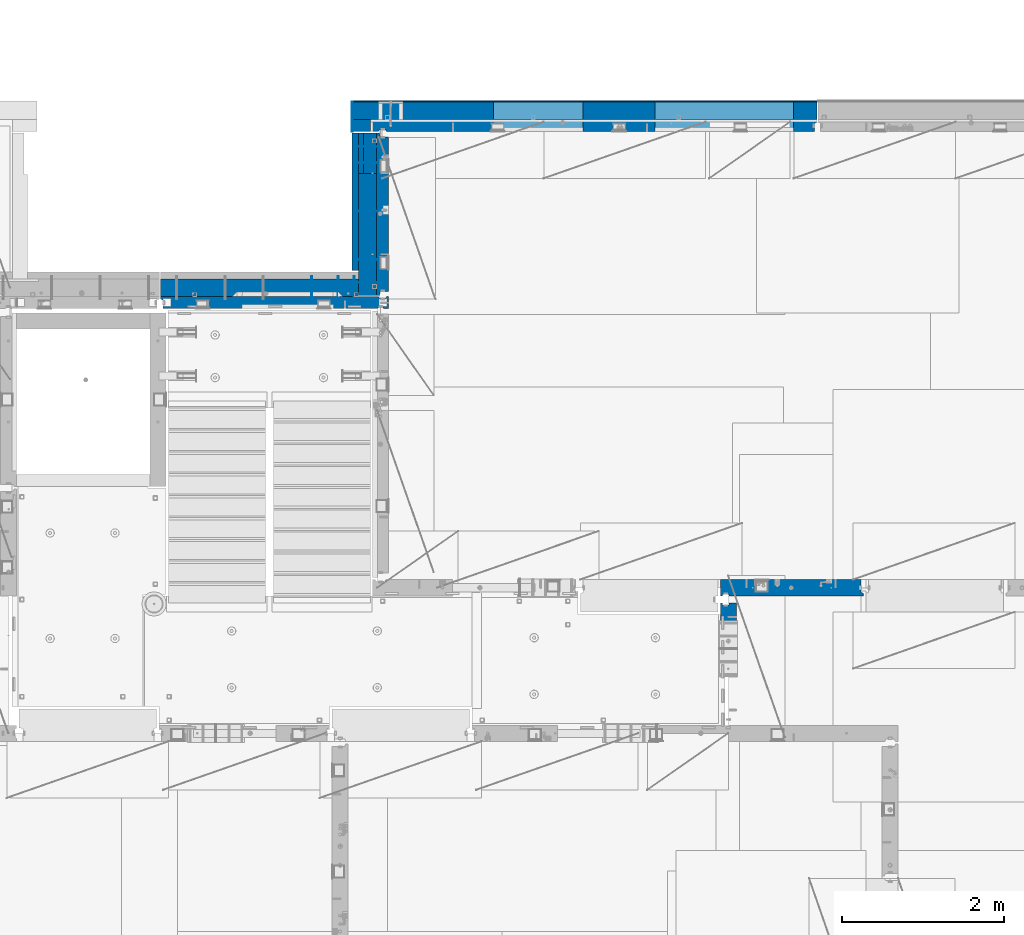
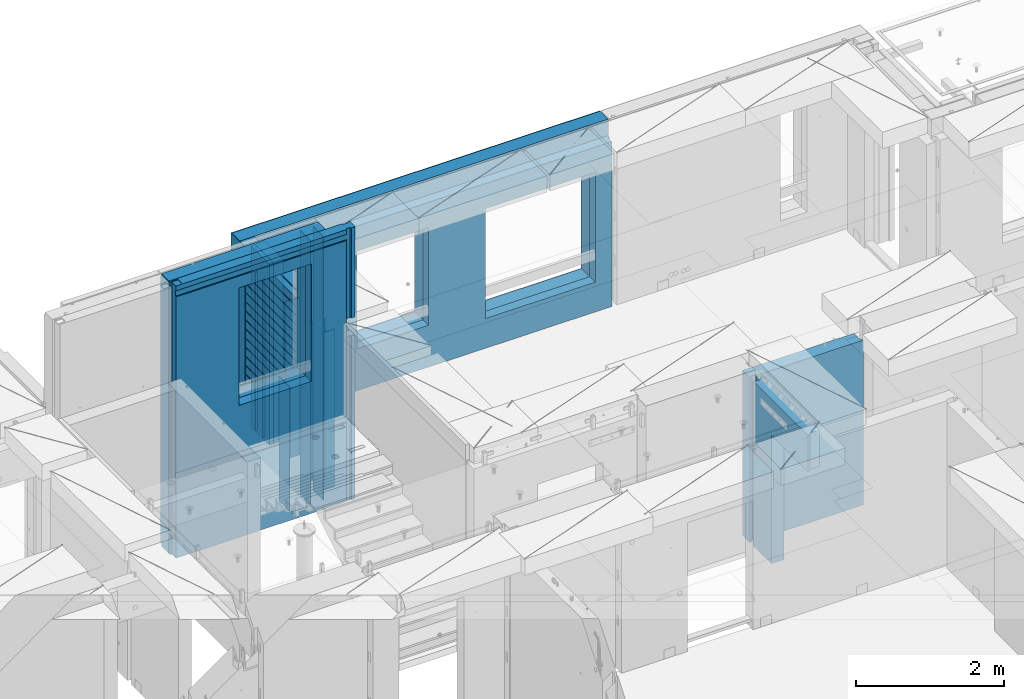
# One storey, part 219 of 325: 22 walls, 7 elements without a shape of their own.
"""IFC2X3 building model written with IfcOpenShell, lengths in millimetres."""

import ifcopenshell
import ifcopenshell.guid

model = None  # the IFC model being written
_history = None  # IfcOwnerHistory: only IFC2X3 demands one
_inside = {}  # id of a spatial element -> (the spatial element, [elements in it])
_under = {}  # id of a project, library or spatial element -> (it, [spatial elements below it])
_declared = {}  # id of a project -> (the project, [libraries it declares])
_typed = {}  # id of a type object -> (the type object, [elements of that type])
_made_of = {}  # id of a material, layer set ... -> (it, [elements and type objects made of it])


def new_model(schema):
    """Start an empty IFC model of exactly this schema.

    Asked for "IFC4X3", IfcOpenShell would pick the latest addendum, in which some entities
    have other attributes; the version numbers below select the first issue.
    IFC2X3 requires an IfcOwnerHistory on every rooted entity: one is made here for all.
    """
    global model, _history
    if schema == "IFC4X3":
        model = ifcopenshell.file(schema_version=(4, 3, 0, 0))
    else:
        model = ifcopenshell.file(schema=schema)
    _inside.clear()
    _under.clear()
    _declared.clear()
    _typed.clear()
    _made_of.clear()
    _history = None
    if model.schema == "IFC2X3":
        org = make("IfcOrganization", Name="unknown")
        user = make(
            "IfcPersonAndOrganization",
            ThePerson=make("IfcPerson", FamilyName="unknown"),
            TheOrganization=org,
        )
        app = make(
            "IfcApplication",
            ApplicationDeveloper=org,
            Version="unknown",
            ApplicationFullName="unknown",
            ApplicationIdentifier="unknown",
        )
        _history = make(
            "IfcOwnerHistory",
            OwningUser=user,
            OwningApplication=app,
            ChangeAction="ADDED",
            CreationDate=0,
        )
    return model


def make(cls, **values):
    """One entity of the class cls with the attributes given. An attribute that is None is left unset."""
    return model.create_entity(
        cls, **{name: value for name, value in values.items() if value is not None}
    )


def rooted(cls, **values):
    """An entity with a GlobalId (a new one), such as an element, a storey or a relation."""
    return make(cls, GlobalId=ifcopenshell.guid.new(), OwnerHistory=_history, **values)


def si_unit(unit_type, name, prefix=None):
    """IfcSIUnit, for example si_unit("LENGTHUNIT", "METRE", prefix="MILLI")."""
    return make("IfcSIUnit", UnitType=unit_type, Prefix=prefix, Name=name)


def assignment(units):
    """IfcUnitAssignment: the units of a project."""
    return None if units is None else make("IfcUnitAssignment", Units=units)


def point(xyz):
    """IfcCartesianPoint."""
    return None if xyz is None else make("IfcCartesianPoint", Coordinates=xyz)


def direction(xyz):
    """IfcDirection."""
    return None if xyz is None else make("IfcDirection", DirectionRatios=xyz)


def frame(location, z_axis=None, x_axis=None):
    """IfcAxis2Placement3D, a coordinate frame: its origin and axes. An axis left out is left unset."""
    return make(
        "IfcAxis2Placement3D",
        Location=point(location),
        Axis=direction(z_axis),
        RefDirection=direction(x_axis),
    )


def origin_with_axes():
    """The frame at (0, 0, 0) with the z axis (0, 0, 1) and the x axis (1, 0, 0) written out."""
    return frame((0.0, 0.0, 0.0), z_axis=(0.0, 0.0, 1.0), x_axis=(1.0, 0.0, 0.0))


def place(relative_to, where):
    """IfcLocalPlacement: puts the frame where relative to a parent placement (None: the world)."""
    return make(
        "IfcLocalPlacement", PlacementRelTo=relative_to, RelativePlacement=where
    )


def context(
    kind, dimensions, precision=None, world=None, true_north=None, identifier=None
):
    """IfcGeometricRepresentationContext, for example the 3D "Model" context."""
    return make(
        "IfcGeometricRepresentationContext",
        ContextIdentifier=identifier,
        ContextType=kind,
        CoordinateSpaceDimension=dimensions,
        Precision=precision,
        WorldCoordinateSystem=world,
        TrueNorth=true_north,
    )


def subcontext(parent, identifier, kind, view, scale=None):
    """IfcGeometricRepresentationSubContext, for example "Body" below "Model"."""
    return make(
        "IfcGeometricRepresentationSubContext",
        ContextIdentifier=identifier,
        ContextType=kind,
        ParentContext=parent,
        TargetScale=scale,
        TargetView=view,
    )


def project(units=None, contexts=None):
    """IfcProject with its units and contexts."""
    return rooted(
        "IfcProject",
        Name="project",
        RepresentationContexts=contexts,
        UnitsInContext=assignment(units),
    )


def spatial(cls, under=None, at=None, **own):
    """A site, building, storey or space (cls), placed at a placement, below another one or the project."""
    s = rooted(cls, ObjectPlacement=at, **own)
    if under is not None:
        _under.setdefault(under.id(), (under, []))[1].append(s)
    return s


def faces_of(points, faces, orient=None, outer=None):
    """IfcFace entities. A face is a list of loops; a loop is a list of indices into points, from 0.

    orient and outer hold one flag for each loop. By default every Orientation is true, the
    first loop of a face is its IfcFaceOuterBound and the others are IfcFaceBound.
    """
    made = []
    for i, loops in enumerate(faces):
        bounds = []
        for j, loop in enumerate(loops):
            is_outer = j == 0 if outer is None else outer[i][j]
            bounds.append(
                make(
                    "IfcFaceOuterBound" if is_outer else "IfcFaceBound",
                    Bound=make("IfcPolyLoop", Polygon=[points[k] for k in loop]),
                    Orientation=True if orient is None else orient[i][j],
                )
            )
        made.append(make("IfcFace", Bounds=bounds))
    return made


def faceted_brep(points, faces, orient=None, outer=None, voids=None):
    """IfcFacetedBrep: a solid bounded by flat faces; with voids (closed shells), ...WithVoids."""
    shared = [point(p) for p in points]
    hull = make("IfcClosedShell", CfsFaces=faces_of(shared, faces, orient, outer))
    if voids is None:
        return make("IfcFacetedBrep", Outer=hull)
    return make(
        "IfcFacetedBrepWithVoids",
        Outer=hull,
        Voids=[
            make(cls, CfsFaces=faces_of(shared, fs, o, b)) for cls, fs, o, b in voids
        ],
    )


def shape(context_of_items, identifier, shape_type, items):
    """IfcShapeRepresentation: the items that make up one representation, for example the "Body"."""
    return make(
        "IfcShapeRepresentation",
        ContextOfItems=context_of_items,
        RepresentationIdentifier=identifier,
        RepresentationType=shape_type,
        Items=items,
    )


def material(Name=None, Category=None):
    """IfcMaterial."""
    return make("IfcMaterial", Name=Name, Category=Category)


def made_of(thing, what):
    """Note that an element or type object is made of a material, layer set ...; save() writes the relation."""
    if what is not None:
        _made_of.setdefault(what.id(), (what, []))[1].append(thing)
    return thing


def type_object(cls, material=None, **own):
    """A type object (cls), such as IfcWallType, which elements share."""
    return made_of(rooted(cls, **own), material)


def element(
    cls,
    number,
    at=None,
    inside=None,
    cuts=None,
    type_object=None,
    material=None,
    context=None,
    identifier="Body",
    shape_type=None,
    held_by="IfcProductDefinitionShape",
    body=None,
    shapes=None,
    **own,
):
    """One element of the class cls, such as IfcWall. Its Tag is "e" and its number.

    at: its placement. inside: the storey or other place that contains it. cuts: it is an
    opening in that element (IfcRelVoidsElement). A single representation is given by context,
    identifier, shape_type and body (its items); several are given by shapes. held_by: the class
    of the entity that holds the representations. save() writes the other relations.
    """
    e = rooted(cls, Tag="e%d" % number, ObjectPlacement=at, **own)
    if body is not None:
        shapes = [shape(context, identifier, shape_type, body)]
    if shapes is not None:
        e.Representation = make(held_by, Representations=shapes)
    if inside is not None:
        _inside.setdefault(inside.id(), (inside, []))[1].append(e)
    if cuts is not None:
        rooted(
            "IfcRelVoidsElement", RelatingBuildingElement=cuts, RelatedOpeningElement=e
        )
    if type_object is not None:
        _typed.setdefault(type_object.id(), (type_object, []))[1].append(e)
    return made_of(e, material)


def aggregate(whole, parts):
    """IfcRelAggregates: a whole, such as a stair, and the parts it consists of."""
    return rooted("IfcRelAggregates", RelatingObject=whole, RelatedObjects=parts)


def save(model, path):
    """Write the relations noted so far, then the file.

    IfcRelAggregates (storeys below a building ...), IfcRelContainedInSpatialStructure (elements
    in a storey), IfcRelDefinesByType, IfcRelAssociatesMaterial and IfcRelDeclares: one each for
    every whole, place, type object, material and project.
    """
    for whole, parts in _under.values():
        aggregate(whole, parts)
    for where, things in _inside.values():
        rooted(
            "IfcRelContainedInSpatialStructure",
            RelatedElements=things,
            RelatingStructure=where,
        )
    for kind, things in _typed.values():
        rooted("IfcRelDefinesByType", RelatedObjects=things, RelatingType=kind)
    for what, things in _made_of.values():
        rooted("IfcRelAssociatesMaterial", RelatedObjects=things, RelatingMaterial=what)
    for by, libraries in _declared.values():
        rooted("IfcRelDeclares", RelatingContext=by, RelatedDefinitions=libraries)
    model.write(path)


model = new_model("IFC2X3")

# Units and contexts
model_context = context("Model", 3, precision=1e-05, world=origin_with_axes())
body_context = subcontext(model_context, "Body", "Model", "MODEL_VIEW")
ifc_project = project(units=[si_unit("LENGTHUNIT", "METRE", prefix="MILLI"), si_unit("AREAUNIT", "SQUARE_METRE"), si_unit("VOLUMEUNIT", "CUBIC_METRE"), si_unit("MASSUNIT", "GRAM", prefix="KILO"), si_unit("TIMEUNIT", "SECOND"), si_unit("PLANEANGLEUNIT", "RADIAN"), si_unit("SOLIDANGLEUNIT", "STERADIAN"), si_unit("THERMODYNAMICTEMPERATUREUNIT", "DEGREE_CELSIUS"), si_unit("LUMINOUSINTENSITYUNIT", "LUMEN")], contexts=[model_context])

# Site, building, storey
site_placement = place(None, origin_with_axes())
site = spatial("IfcSite", under=ifc_project, at=site_placement, CompositionType="ELEMENT")
building_placement = place(site_placement, origin_with_axes())
building = spatial("IfcBuilding", under=site, at=building_placement, CompositionType="ELEMENT")
storey_placement = place(building_placement, origin_with_axes())
storey = spatial("IfcBuildingStorey", under=building, at=storey_placement, Name="1", CompositionType="ELEMENT", Elevation=0.0)

# Assembly, walls
assembly_1_placement = place(storey_placement, origin_with_axes())
assembly_1 = element("IfcElementAssembly", 1, at=assembly_1_placement, inside=storey, Name="(PD)", AssemblyPlace="NOTDEFINED", PredefinedType="REINFORCEMENT_UNIT")
ifc_material_1 = material(Name="Undefined")
wall_type_1 = type_object("IfcWallType", PredefinedType="NOTDEFINED")
wall_1_placement = place(assembly_1_placement, frame((22010.0, 21035.0, 83115.0), z_axis=(0.0, 0.0, 1.0), x_axis=(1.0, 0.0, 0.0)))
wall_1 = element("IfcWall", 2, at=wall_1_placement, type_object=wall_type_1, material=ifc_material_1, Name="(PD)", context=body_context, shape_type="Brep", body=[
    faceted_brep([(0.0, 5.0, -1300.0), (0.0, 5.0, 1300.0), (280.0, 5.0, 1300.0), (280.0, 5.0, -1300.0), (0.0, -5.0, 1300.0), (280.0, -5.0, 1300.0), (0.0, -5.0, -1300.0), (280.0, -5.0, -1300.0)], [[[0, 1, 2, 3]], [[1, 4, 5, 2]], [[4, 6, 7, 5]], [[6, 0, 3, 7]], [[5, 7, 3, 2]], [[6, 4, 1, 0]]]),
])
wall_2_placement = place(assembly_1_placement, frame((22010.0, 21635.0, 83115.0), z_axis=(0.0, 0.0, 1.0), x_axis=(1.0, 0.0, 0.0)))
wall_2 = element("IfcWall", 3, at=wall_2_placement, type_object=wall_type_1, material=ifc_material_1, Name="(PD)", context=body_context, shape_type="Brep", body=[
    faceted_brep([(0.0, 5.0, -1300.0), (0.0, 5.0, 1300.0), (280.0, 5.0, 1300.0), (280.0, 5.0, -1300.0), (0.0, -5.0, 1300.0), (280.0, -5.0, 1300.0), (0.0, -5.0, -1300.0), (280.0, -5.0, -1300.0)], [[[0, 1, 2, 3]], [[1, 4, 5, 2]], [[4, 6, 7, 5]], [[6, 0, 3, 7]], [[5, 7, 3, 2]], [[6, 4, 1, 0]]]),
])
wall_3_placement = place(assembly_1_placement, frame((22010.0, 22235.0, 83115.0), z_axis=(0.0, 0.0, 1.0), x_axis=(1.0, 0.0, 0.0)))
wall_3 = element("IfcWall", 4, at=wall_3_placement, type_object=wall_type_1, material=ifc_material_1, Name="(PD)", context=body_context, shape_type="Brep", body=[
    faceted_brep([(0.0, 5.0, -1300.0), (0.0, 5.0, 1300.0), (280.0, 5.0, 1300.0), (280.0, 5.0, -1300.0), (0.0, -5.0, 1300.0), (280.0, -5.0, 1300.0), (0.0, -5.0, -1300.0), (280.0, -5.0, -1300.0)], [[[0, 1, 2, 3]], [[1, 4, 5, 2]], [[4, 6, 7, 5]], [[6, 0, 3, 7]], [[5, 7, 3, 2]], [[6, 4, 1, 0]]]),
])

# Assembly, wall
assembly_2_placement = place(storey_placement, origin_with_axes())
assembly_2 = element("IfcElementAssembly", 5, at=assembly_2_placement, inside=storey, Name="Steel Assembly", AssemblyPlace="NOTDEFINED", PredefinedType="NOTDEFINED")
wall_4_placement = place(assembly_2_placement, frame((22269.7, 20754.999997361, 83110.0), z_axis=(0.0, 0.0, 1.0), x_axis=(-1.0, 3.00000001838171e-08, 0.0)))
wall_4 = element("IfcWall", 6, at=wall_4_placement, type_object=wall_type_1, material=ifc_material_1, Name="(PD)", context=body_context, shape_type="Brep", body=[
    faceted_brep([(0.0, 5.0, -1300.0), (0.0, 5.0, 1300.0), (280.0, 5.0, 1300.0), (280.0, 5.0, -1300.0), (0.0, -5.0, 1300.0), (280.0, -5.0, 1300.0), (0.0, -5.0, -1300.0), (280.0, -5.0, -1300.0)], [[[0, 1, 2, 3]], [[1, 4, 5, 2]], [[4, 6, 7, 5]], [[6, 0, 3, 7]], [[5, 7, 3, 2]], [[6, 4, 1, 0]]]),
])
aggregate(assembly_2, [wall_4])

# Wall
wall_5_placement = place(assembly_1_placement, frame((22010.0, 22435.0, 83115.0), z_axis=(0.0, 0.0, 1.0), x_axis=(1.0, 0.0, 0.0)))
wall_5 = element("IfcWall", 7, at=wall_5_placement, type_object=wall_type_1, material=ifc_material_1, Name="(PD)", context=body_context, shape_type="Brep", body=[
    faceted_brep([(0.0, 5.0, -1300.0), (0.0, 5.0, 1300.0), (280.0, 5.0, 1300.0), (280.0, 5.0, -1300.0), (0.0, -5.0, 1300.0), (280.0, -5.0, 1300.0), (0.0, -5.0, -1300.0), (280.0, -5.0, -1300.0)], [[[0, 1, 2, 3]], [[1, 4, 5, 2]], [[4, 6, 7, 5]], [[6, 0, 3, 7]], [[5, 7, 3, 2]], [[6, 4, 1, 0]]]),
])

# Assembly, wall
assembly_3_placement = place(storey_placement, origin_with_axes())
assembly_3 = element("IfcElementAssembly", 8, at=assembly_3_placement, inside=storey, AssemblyPlace="NOTDEFINED", PredefinedType="REINFORCEMENT_UNIT")
ifc_material_2 = material(Name="CONCRETE/C25/30")
wall_type_2 = type_object("IfcWallType", PredefinedType="NOTDEFINED")
wall_6_placement = place(assembly_3_placement, frame((26510.0014364077, 16980.0, 83112.5), z_axis=(0.0, 0.0, 1.0), x_axis=(1.0, 0.0, 0.0)))
wall_6 = element("IfcWall", 9, at=wall_6_placement, type_object=wall_type_2, material=ifc_material_2, context=body_context, shape_type="Brep", body=[
    faceted_brep([(1739.99847412109, 100.0, 1357.5), (1739.99847412109, -57.0, 1357.5), (1739.99847412109, -57.0, -1357.5), (1739.99847412109, 100.0, -1357.5), (1769.99847412109, -70.0, 1357.5), (1769.99847412109, -70.0, -1357.5), (0.0, -100.0, -1357.5), (0.0, -100.0, 1357.5), (0.0, 100.0, 1357.5), (0.0, 100.0, -1357.5), (29.998563592264, -100.0, -1357.5), (29.998563592264, -100.0, 1357.5), (29.998563592264, -80.0008544921875, -1357.5), (29.998563592264, -80.0008544921875, 1357.5), (109.998563592264, -80.0008544921875, -1357.5), (109.998563592264, -80.0008544921875, 1357.5), (109.998563592264, -100.0, -1357.5), (109.998563592264, -100.0, 1357.5), (1769.99847412109, -100.0, -1357.5), (1769.99847412109, -100.0, 1357.5)], [[[0, 1, 2, 3]], [[4, 5, 2, 1]], [[6, 7, 8, 9]], [[7, 6, 10, 11]], [[11, 10, 12, 13]], [[13, 12, 14, 15]], [[15, 14, 16, 17]], [[18, 19, 17, 16]], [[0, 8, 7, 11, 13, 15, 17, 19, 4, 1]], [[9, 8, 0, 3]], [[18, 16, 14, 12, 10, 6, 9, 3, 2, 5]], [[19, 18, 5, 4]]]),
])
aggregate(assembly_3, [wall_6])

assembly_4_placement = place(storey_placement, origin_with_axes())
assembly_4 = element("IfcElementAssembly", 10, at=assembly_4_placement, inside=storey, AssemblyPlace="NOTDEFINED", PredefinedType="REINFORCEMENT_UNIT")
wall_7_placement = place(assembly_4_placement, frame((26609.9991475894, 15280.0004107749, 83112.5), z_axis=(0.0, 0.0, 1.0), x_axis=(0.0, 1.0, 0.0)))
wall_7 = element("IfcWall", 11, at=wall_7_placement, type_object=wall_type_2, material=ifc_material_2, context=body_context, shape_type="Brep", body=[
    faceted_brep([(1509.99949975397, 70.0, 1357.5), (1489.99949975397, 70.0, 1357.5), (1489.99949975397, 70.0, -1357.5), (1509.99949975397, 70.0, -1357.5), (1489.99949975397, -10.0, 1357.5), (1489.99949975397, -10.0, -1357.5), (1509.99949975397, -10.0, 1357.5), (1509.99949975397, -10.0, -1357.5), (29.9995892251427, 70.0, 1357.5), (29.9995892251427, 70.0, 762.5), (59.9995892251427, 57.0, 762.5), (59.9995892251427, 57.0, 1357.5), (29.9995892251427, 100.0, 1357.5), (29.9995892251427, 100.0, 762.5), (1509.99949975397, 100.0, 1357.5), (1509.99949975397, 100.0, -1357.5), (1019.99979369292, 100.0, -1357.5), (1019.99979369292, 100.0, 762.5), (1019.99979369292, -100.0, 762.5), (1019.99979369292, -100.0, -1357.5), (59.9995892251427, -100.0, 762.5), (59.9995892251427, -100.0, 1357.5), (1509.99949975397, -100.0, -1357.5), (1509.99949975397, -100.0, 1357.5)], [[[0, 1, 2, 3]], [[4, 5, 2, 1]], [[6, 7, 5, 4]], [[8, 9, 10, 11]], [[12, 13, 9, 8]], [[12, 14, 15, 16, 17, 13]], [[18, 17, 16, 19]], [[9, 13, 17, 18, 20, 10]], [[21, 11, 10, 20]], [[18, 19, 22, 23, 21, 20]], [[1, 0, 14, 12, 8, 11, 21, 23, 6, 4]], [[15, 14, 0, 3]], [[22, 19, 16, 15, 3, 2, 5, 7]], [[23, 22, 7, 6]]]),
])
aggregate(assembly_4, [wall_7])

# Wall
ifc_material_3 = material(Name="COS5gt")
wall_type_3 = type_object("IfcWallType", PredefinedType="NOTDEFINED")
wall_8_placement = place(assembly_1_placement, frame((22150.0, 20595.0, 83247.5), z_axis=(0.0, 0.0, 1.0), x_axis=(0.0, 1.0, 0.0)))
wall_8 = element("IfcWall", 12, at=wall_8_placement, type_object=wall_type_3, material=ifc_material_3, context=body_context, shape_type="Brep", body=[
    faceted_brep([(285.0, 110.0, -1492.5), (285.0, 110.0, -1442.5), (285.0, 90.0, -1442.5), (285.0, 90.0, -1492.5), (1510.0, 90.0, -1442.5), (1510.0, 110.0, -1442.5), (1510.0, 90.0, -1492.5), (0.0, -110.0, -1492.5), (0.0, -110.0, 1492.5), (0.0, 110.0, 1492.5), (0.0, 110.0, -1492.5), (1510.0, -110.0, -1492.5), (1510.0, -110.0, 1492.5), (285.0, 110.0, 1492.5), (1510.0, 90.0, 1492.5), (285.0, 90.0, 1492.5), (285.0, 90.0, 1442.5), (285.0, 110.0, 1442.5), (1510.0, 90.0, 1442.5), (1510.0, 110.0, 1442.5)], [[[0, 1, 2, 3]], [[4, 2, 1, 5]], [[6, 3, 2, 4]], [[7, 8, 9, 10]], [[8, 7, 11, 12]], [[13, 9, 8, 12, 14, 15]], [[15, 16, 17, 13]], [[14, 18, 16, 15]], [[19, 17, 16, 18]], [[0, 10, 9, 13, 17, 19, 5, 1]], [[11, 7, 10, 0, 3, 6]], [[19, 18, 14, 12, 11, 6, 4, 5]]]),
])

# Assembly, walls
assembly_5_placement = place(storey_placement, origin_with_axes())
assembly_5 = element("IfcElementAssembly", 13, at=assembly_5_placement, inside=storey, AssemblyPlace="NOTDEFINED", PredefinedType="REINFORCEMENT_UNIT")
ifc_material_4 = material()
wall_9_placement = place(assembly_5_placement, frame((22075.0, 22620.0, 83247.5), z_axis=(0.0, 0.0, 1.0), x_axis=(0.0, 1.0, 0.0)))
wall_9 = element("IfcWall", 14, at=wall_9_placement, type_object=wall_type_3, material=ifc_material_4, context=body_context, shape_type="Brep", body=[
    faceted_brep([(0.0, 110.0, -1492.5), (0.0, 110.0, 1492.5), (150.0, 110.0, 1492.5), (150.0, 110.0, -1492.5), (0.0, -110.0, 1492.5), (150.0, -110.0, 1492.5), (0.0, -110.0, -1492.5), (150.0, -110.0, -1492.5)], [[[0, 1, 2, 3]], [[1, 4, 5, 2]], [[4, 6, 7, 5]], [[6, 0, 3, 7]], [[5, 7, 3, 2]], [[6, 4, 1, 0]]]),
])
wall_10_placement = place(assembly_5_placement, frame((22260.0, 22880.0, 83247.5), z_axis=(0.0, 0.0, 1.0), x_axis=(1.0, 0.0, 0.0)))
wall_10 = element("IfcWall", 15, at=wall_10_placement, type_object=wall_type_3, material=ifc_material_4, context=body_context, shape_type="Brep", body=[
    faceted_brep([(-295.0, 110.0, 1492.5), (-295.0, -110.0, 1492.5), (5445.0, -110.0, 1492.5), (5445.0, 110.0, 1492.5), (-295.0, -110.0, -1492.5), (-295.0, 110.0, -1492.5), (5445.0, 110.0, -1492.5), (5445.0, -110.0, -1492.5), (3445.00100868184, 110.0, -1002.5), (5155.00100868184, 110.0, -1002.5), (5155.00100868184, 110.0, 807.5), (3445.00100868184, 110.0, 807.5), (1444.99910133321, 110.0, -802.5), (2554.99910133321, 110.0, -802.5), (2554.99910133321, 110.0, 807.5), (1444.99910133321, 110.0, 807.5), (1444.99910133321, -110.0, -802.5), (2554.99910133321, -110.0, -802.5), (1444.99910133321, -110.0, 807.5), (2554.99910133321, -110.0, 807.5), (3445.00100868184, -110.0, -1002.5), (3445.00100868184, -110.0, 807.5), (5155.00100868184, -110.0, 807.5), (5155.00100868184, -110.0, -1002.5)], [[[0, 1, 2, 3]], [[4, 1, 0, 5]], [[4, 5, 6, 7]], [[2, 7, 6, 3]], [[5, 0, 3, 6], [8, 9, 10, 11], [12, 13, 14, 15]], [[12, 16, 17, 13]], [[15, 18, 16, 12]], [[14, 19, 18, 15]], [[13, 17, 19, 14]], [[1, 4, 7, 2], [20, 21, 22, 23], [16, 18, 19, 17]], [[10, 22, 21, 11]], [[9, 23, 22, 10]], [[8, 20, 23, 9]], [[11, 21, 20, 8]]]),
])

# Wall
ifc_material_5 = material(Name="CONCRETE/C30/37")
wall_type_4 = type_object("IfcWallType", PredefinedType="NOTDEFINED")
wall_11_placement = place(assembly_1_placement, frame((21997.5, 20900.0, 83247.5), z_axis=(0.0, 0.0, 1.0), x_axis=(0.0, 1.0, 0.0)))
wall_11 = element("IfcWall", 16, at=wall_11_placement, type_object=wall_type_4, material=ifc_material_5, context=body_context, shape_type="Brep", body=[
    faceted_brep([(1705.0, 42.5, 1343.0), (0.0, 42.5, 1342.99999994476), (-3.63797880709171e-12, 32.4999992507037, 1344.99999999926), (1705.0, 32.5, 1345.0), (1705.0, 32.5, 1355.0), (-3.63797880709171e-12, 32.4999991127006, 1355.00000040044), (0.0, 42.5, 1356.99999988925), (1705.0, 42.5, 1357.0), (1705.0, 32.5, 1205.0), (0.0, 32.4999991127006, 1205.00000040044), (0.0, 42.5, 1206.99999988925), (1705.0, 42.5, 1207.0), (1705.0, 32.5, 1195.0), (0.0, 32.4999992507037, 1194.99999999926), (1705.0, 42.5, 1193.0), (0.0, 42.5, 1192.99999994476), (1705.0, 42.5, 1057.0), (0.0, 42.5, 1056.99999988925), (1705.0, 32.5, 1055.0), (0.0, 32.4999991127006, 1055.00000040044), (1705.0, 32.5, 1045.0), (0.0, 32.4999992507037, 1044.99999999926), (1705.0, 42.5, 1043.0), (0.0, 42.5, 1042.99999994476), (1705.0, 42.5, 907.0), (0.0, 42.5, 906.999999889245), (1705.0, 32.5, 905.0), (0.0, 32.4999991127006, 905.00000040044), (1705.0, 32.5, 895.0), (0.0, 32.4999992507037, 894.999999999258), (1705.0, 42.5, 893.0), (0.0, 42.5, 892.999999944761), (1705.0, 42.5, 757.0), (0.0, 42.5, 756.999999889245), (1705.0, 32.5, 755.0), (0.0, 32.4999991127006, 755.00000040044), (1705.0, 32.5, 745.0), (0.0, 32.4999992507037, 744.999999999258), (1705.0, 42.5, 743.0), (0.0, 42.5, 742.999999944761), (1705.0, 42.5, 607.0), (0.0, 42.5, 606.999999889245), (1705.0, 32.5, 605.0), (3.63797880709171e-12, 32.4999991127006, 605.00000040044), (1705.0, 32.5, 595.0), (3.63797880709171e-12, 32.4999992507037, 594.999999999258), (1705.0, 42.5, 593.0), (0.0, 42.5, 592.999999944761), (1705.0, 42.5, 457.0), (0.0, 42.5, 456.999999889245), (1705.0, 32.5, 455.0), (0.0, 32.4999991127006, 455.00000040044), (1705.0, 32.5, 445.0), (0.0, 32.4999992507037, 444.999999999258), (1705.0, 42.5, 443.0), (0.0, 42.5, 442.999999944761), (1705.0, 42.5, 307.0), (0.0, 42.5, 306.999999889245), (1705.0, 32.5, 305.0), (-3.63797880709171e-12, 32.4999991127006, 305.00000040044), (1705.0, 32.5, 295.0), (-3.63797880709171e-12, 32.4999992507037, 294.999999999258), (1705.0, 42.5, 293.0), (0.0, 42.5, 292.999999944761), (1705.0, 42.5, 157.0), (0.0, 42.5, 156.999999889245), (1705.0, 32.5, 155.0), (-3.63797880709171e-12, 32.4999991127006, 155.00000040044), (1705.0, 32.5, 145.0), (-3.63797880709171e-12, 32.4999992507037, 144.999999999258), (1705.0, 42.5, 143.0), (0.0, 42.5, 142.999999944761), (1705.0, 42.5, 7.0), (0.0, 42.5, 6.99999988924537), (1705.0, 32.5, 5.0), (0.0, 32.4999991127006, 5.0000004004396), (1705.0, 32.5, -5.0), (0.0, 32.4999992507037, -5.00000000074215), (1705.0, 42.5, -7.0), (0.0, 42.5, -7.00000005523907), (1705.0, 42.5, -143.0), (0.0, 42.5, -143.000000110755), (1705.0, 32.5, -145.0), (3.63797880709171e-12, 32.4999991127006, -144.99999959956), (1705.0, 32.5, -155.0), (3.63797880709171e-12, 32.4999992507037, -155.000000000742), (1705.0, 42.5, -157.0), (0.0, 42.5, -157.000000055239), (1705.0, 42.5, -293.0), (0.0, 42.5, -293.000000110755), (1705.0, 32.5, -295.0), (0.0, 32.4999991127006, -294.99999959956), (1705.0, 32.5, -305.0), (0.0, 32.4999992507037, -305.000000000742), (1705.0, 42.5, -307.0), (0.0, 42.5, -307.000000055239), (1705.0, 42.5, -443.0), (0.0, 42.5, -443.000000110755), (1705.0, 32.5, -445.0), (0.0, 32.4999991127006, -444.99999959956), (1705.0, 32.5, -455.0), (0.0, 32.4999992507037, -455.000000000742), (1705.0, 42.5, -457.0), (0.0, 42.5, -457.000000055239), (1705.0, 42.5, -593.0), (0.0, 42.5, -593.000000110755), (1705.0, 32.5, -595.0), (3.63797880709171e-12, 32.4999991127006, -594.99999959956), (1705.0, 32.5, -605.0), (3.63797880709171e-12, 32.4999992507037, -605.000000000742), (1705.0, 42.5, -607.0), (0.0, 42.5, -607.000000055239), (1705.0, 42.5, -743.0), (0.0, 42.5, -743.000000110755), (1705.0, 32.5, -745.0), (0.0, 32.4999991127006, -744.99999959956), (1705.0, 32.5, -755.0), (0.0, 32.4999992507037, -755.000000000742), (1705.0, 42.5, -757.0), (0.0, 42.5, -757.000000055239), (1705.0, 42.5, -893.0), (0.0, 42.5, -893.000000110755), (1705.0, 32.5, -895.0), (0.0, 32.4999991127006, -894.99999959956), (1705.0, 32.5, -905.0), (0.0, 32.4999992507037, -905.000000000742), (1705.0, 42.5, -907.0), (0.0, 42.5, -907.000000055239), (1705.0, 42.5, -1043.0), (0.0, 42.5, -1043.00000011075), (1705.0, 32.5, -1045.0), (0.0, 32.4999991127006, -1044.99999959956), (1705.0, 32.5, -1055.0), (0.0, 32.4999992507037, -1055.00000000074), (1705.0, 42.5, -1057.0), (0.0, 42.5, -1057.00000005524), (1705.0, 42.5, -1193.0), (0.0, 42.5, -1193.00000011075), (1705.0, 32.5, -1195.0), (0.0, 32.4999991127006, -1194.99999959956), (1705.0, 32.5, -1205.0), (0.0, 32.4999992507037, -1205.00000000074), (1705.0, 42.5, -1207.0), (0.0, 42.5, -1207.00000005524), (1705.0, 42.5, -1343.0), (0.0, 42.5, -1343.00000011075), (1705.0, 32.5, -1345.0), (0.0, 32.4999991127006, -1344.99999959956), (1705.0, 32.5, -1355.0), (0.0, 32.4999992507037, -1355.00000000074), (1705.0, 42.5, -1357.0), (0.0, 42.5, -1357.00000005524), (1705.0, 42.5, -1492.5), (0.0, 42.5, -1492.5), (0.0, -42.5, -1492.5), (1705.0, -42.5, -1492.5), (0.0, -42.5, 1492.5), (1705.0, -42.5, 1492.5), (0.0, 42.5, 1492.5), (1705.0, 42.5, 1492.5)], [[[0, 1, 2, 3]], [[4, 5, 6, 7]], [[3, 2, 5, 4]], [[8, 9, 10, 11]], [[12, 13, 9, 8]], [[14, 15, 13, 12]], [[16, 17, 15, 14]], [[18, 19, 17, 16]], [[20, 21, 19, 18]], [[22, 23, 21, 20]], [[24, 25, 23, 22]], [[26, 27, 25, 24]], [[28, 29, 27, 26]], [[30, 31, 29, 28]], [[32, 33, 31, 30]], [[34, 35, 33, 32]], [[36, 37, 35, 34]], [[38, 39, 37, 36]], [[40, 41, 39, 38]], [[42, 43, 41, 40]], [[44, 45, 43, 42]], [[46, 47, 45, 44]], [[48, 49, 47, 46]], [[50, 51, 49, 48]], [[52, 53, 51, 50]], [[54, 55, 53, 52]], [[56, 57, 55, 54]], [[58, 59, 57, 56]], [[60, 61, 59, 58]], [[62, 63, 61, 60]], [[64, 65, 63, 62]], [[66, 67, 65, 64]], [[68, 69, 67, 66]], [[70, 71, 69, 68]], [[72, 73, 71, 70]], [[74, 75, 73, 72]], [[76, 77, 75, 74]], [[78, 79, 77, 76]], [[80, 81, 79, 78]], [[82, 83, 81, 80]], [[84, 85, 83, 82]], [[86, 87, 85, 84]], [[88, 89, 87, 86]], [[90, 91, 89, 88]], [[92, 93, 91, 90]], [[94, 95, 93, 92]], [[96, 97, 95, 94]], [[98, 99, 97, 96]], [[100, 101, 99, 98]], [[102, 103, 101, 100]], [[104, 105, 103, 102]], [[106, 107, 105, 104]], [[108, 109, 107, 106]], [[110, 111, 109, 108]], [[112, 113, 111, 110]], [[114, 115, 113, 112]], [[116, 117, 115, 114]], [[118, 119, 117, 116]], [[120, 121, 119, 118]], [[122, 123, 121, 120]], [[124, 125, 123, 122]], [[126, 127, 125, 124]], [[128, 129, 127, 126]], [[130, 131, 129, 128]], [[132, 133, 131, 130]], [[134, 135, 133, 132]], [[136, 137, 135, 134]], [[138, 139, 137, 136]], [[140, 141, 139, 138]], [[142, 143, 141, 140]], [[144, 145, 143, 142]], [[146, 147, 145, 144]], [[148, 149, 147, 146]], [[150, 151, 149, 148]], [[152, 153, 151, 150]], [[154, 153, 152, 155]], [[156, 154, 155, 157]], [[158, 156, 157, 159]], [[158, 159, 7, 6]], [[2, 1, 10, 9, 13, 15, 17, 19, 21, 23, 25, 27, 29, 31, 33, 35, 37, 39, 41, 43, 45, 47, 49, 51, 53, 55, 57, 59, 61, 63, 65, 67, 69, 71, 73, 75, 77, 79, 81, 83, 85, 87, 89, 91, 93, 95, 97, 99, 101, 103, 105, 107, 109, 111, 113, 115, 117, 119, 121, 123, 125, 127, 129, 131, 133, 135, 137, 139, 141, 143, 145, 147, 149, 151, 153, 154, 156, 158, 6, 5]], [[11, 10, 1, 0]], [[159, 157, 155, 152, 150, 148, 146, 144, 142, 140, 138, 136, 134, 132, 130, 128, 126, 124, 122, 120, 118, 116, 114, 112, 110, 108, 106, 104, 102, 100, 98, 96, 94, 92, 90, 88, 86, 84, 82, 80, 78, 76, 74, 72, 70, 68, 66, 64, 62, 60, 58, 56, 54, 52, 50, 48, 46, 44, 42, 40, 38, 36, 34, 32, 30, 28, 26, 24, 22, 20, 18, 16, 14, 12, 8, 11, 0, 3, 4, 7]]]),
])

wall_type_5 = type_object("IfcWallType", PredefinedType="NOTDEFINED")
wall_12_placement = place(assembly_1_placement, frame((22335.0, 20595.0, 83112.5), z_axis=(0.0, 0.0, 1.0), x_axis=(0.0, 1.0, 0.0)))
wall_12 = element("IfcWall", 17, at=wall_12_placement, type_object=wall_type_5, material=ifc_material_2, context=body_context, shape_type="Brep", body=[
    faceted_brep([(0.0, 40.0, 1357.5), (0.0, 40.0, -1357.5), (50.0, 27.0, -1357.5), (50.0, 27.0, 1357.5), (50.0, -75.0, 1357.5), (50.0, -75.0, -1357.5), (0.0, 75.0, -1357.5), (0.0, 75.0, 1357.5), (2009.99999772087, 75.0, 1357.5), (2009.99999772087, 75.0, -1357.5), (2009.99999772087, 40.0, 1357.5), (2009.99999772087, 40.0, -1357.5), (1959.99999772087, 27.0, 1357.5), (1959.99999772087, 27.0, -1357.5), (1959.99999772087, -75.0, 1357.5), (1959.99999772087, -75.0, -1357.5)], [[[0, 1, 2, 3]], [[4, 3, 2, 5]], [[6, 7, 8, 9]], [[9, 8, 10, 11]], [[12, 13, 11, 10]], [[14, 15, 13, 12]], [[15, 14, 4, 5]], [[1, 6, 9, 11, 13, 15, 5, 2]], [[7, 6, 1, 0]], [[14, 12, 10, 8, 7, 0, 3, 4]]]),
])

wall_13_placement = place(assembly_5_placement, frame((22185.0, 22695.0, 83112.5), z_axis=(0.0, 0.0, 1.0), x_axis=(1.0, 0.0, 0.0)))
wall_13 = element("IfcWall", 18, at=wall_13_placement, type_object=wall_type_5, material=ifc_material_2, context=body_context, shape_type="Brep", body=[
    faceted_brep([(3520.00100868184, 75.0, 942.5), (3520.00100868184, -75.0000008199713, 942.5), (3520.00100868184, -75.0000000602631, -867.5), (3520.00100868184, 75.0, -867.5), (5230.00100868184, -74.9999996918959, -867.5), (5230.00100868184, 75.0, -867.5), (5230.00100868184, -75.0000004516041, 942.5), (5230.00100868184, 75.0, 942.5), (5490.0, -75.0, 1357.5), (5490.0, -75.0, -1357.5), (5490.0, 24.9999980926514, -1357.5), (5490.0, 24.9999980926514, 1357.5), (5520.0, 45.0, 1357.5), (5520.0, 75.0, 1357.5), (0.0, 75.0, 1357.5), (0.0, -75.0, 1357.5), (100.0, -75.0, 1357.5), (110.0, -55.0000022791319, 1357.5), (190.0, -55.0000022791319, 1357.5), (200.0, -75.0000022791319, 1357.5), (0.0, -75.0, -1357.5), (0.0, 75.0, -1357.5), (100.0, -75.0, -1357.5), (110.0, -55.0000022791319, -1357.5), (190.0, -55.0000022791319, -1357.5), (200.0, -75.0, -1357.5), (5520.0, 75.0, -1357.5), (5520.0, 45.0, -1357.5), (1519.99910133321, 75.0, -667.5), (2629.99910133321, 75.0, -667.5), (2629.99910133321, 75.0, 942.5), (1519.99910133321, 75.0, 942.5), (1519.99910133321, -75.0000005750444, -667.5), (2629.99910133321, -75.0000003359273, -667.5), (1519.99910133321, -75.0000012508099, 942.5), (2629.99910133321, -75.0000010116928, 942.5)], [[[0, 1, 2, 3]], [[3, 2, 4, 5]], [[5, 4, 6, 7]], [[7, 6, 1, 0]], [[8, 9, 10, 11]], [[8, 11, 12, 13, 14, 15, 16, 17, 18, 19]], [[20, 15, 14, 21]], [[15, 20, 22, 16]], [[16, 22, 23, 17]], [[17, 23, 24, 18]], [[19, 18, 24, 25]], [[23, 22, 20, 21, 26, 27, 10, 9, 25, 24]], [[12, 11, 10, 27]], [[26, 13, 12, 27]], [[21, 14, 13, 26], [3, 5, 7, 0], [28, 29, 30, 31]], [[28, 32, 33, 29]], [[31, 34, 32, 28]], [[30, 35, 34, 31]], [[29, 33, 35, 30]], [[9, 8, 19, 25], [2, 1, 6, 4], [32, 34, 35, 33]]]),
])

ifc_material_6 = material(Name="SPU")
wall_type_6 = type_object("IfcWallType", PredefinedType="NOTDEFINED")
wall_14_placement = place(assembly_1_placement, frame((22180.0, 22605.0, 83247.5), z_axis=(0.0, 0.0, 1.0), x_axis=(0.0, -1.0, 0.0)))
wall_14 = element("IfcWall", 19, at=wall_14_placement, type_object=wall_type_6, material=ifc_material_6, context=body_context, shape_type="Brep", body=[
    faceted_brep([(0.0, 80.0, -1492.5), (0.0, 80.0, 1492.5), (500.0, 80.0, 1492.5), (500.0, 80.0, -1492.5), (0.0, -80.0, 1492.5), (500.0, -80.0, 1492.5), (0.0, -80.0, -1492.5), (500.0, -80.0, -1492.5)], [[[0, 1, 2, 3]], [[1, 4, 5, 2]], [[4, 6, 7, 5]], [[6, 0, 3, 7]], [[5, 7, 3, 2]], [[6, 4, 1, 0]]]),
])

wall_type_7 = type_object("IfcWallType", PredefinedType="NOTDEFINED")
wall_15_placement = place(assembly_1_placement, frame((22070.0, 22620.0, 83247.5), z_axis=(0.0, 0.0, 1.0), x_axis=(0.0, -1.0, 0.0)))
wall_15 = element("IfcWall", 20, at=wall_15_placement, type_object=wall_type_7, material=ifc_material_5, context=body_context, shape_type="Brep", body=[
    faceted_brep([(15.0, 30.0, -1492.5), (15.0, 30.0, 1492.5), (515.0, 30.0, 1492.5), (515.0, 30.0, -1492.5), (15.0, -30.0, 1492.5), (515.0, -30.0, 1492.5), (15.0, -30.0, -1492.5), (515.0, -30.0, -1492.5)], [[[0, 1, 2, 3]], [[1, 4, 5, 2]], [[4, 6, 7, 5]], [[6, 0, 3, 7]], [[5, 7, 3, 2]], [[6, 4, 1, 0]]]),
])

aggregate(assembly_1, [wall_1, wall_2, wall_3, wall_14, wall_15, wall_8, wall_5, wall_11, wall_12])

# Assembly, walls
assembly_6_placement = place(storey_placement, origin_with_axes())
assembly_6 = element("IfcElementAssembly", 21, at=assembly_6_placement, inside=storey, AssemblyPlace="NOTDEFINED", PredefinedType="REINFORCEMENT_UNIT")
wall_type_8 = type_object("IfcWallType", PredefinedType="NOTDEFINED")
wall_16_placement = place(assembly_6_placement, frame((21460.0002441406, 20550.0, 82835.0), z_axis=(0.0, 0.0, 1.0), x_axis=(0.0, 1.0, 0.0)))
wall_16 = element("IfcWall", 22, at=wall_16_placement, type_object=wall_type_8, material=ifc_material_1, Name="(PD)", context=body_context, shape_type="Brep", body=[
    faceted_brep([(0.0, 5.0, -1025.0), (0.0, 5.0, 1025.0), (280.0, 5.0, 1025.0), (280.0, 5.0, -1025.0), (0.0, -5.0, 1025.0), (280.0, -5.0, 1025.0), (0.0, -5.0, -1025.0), (280.0, -5.0, -1025.0)], [[[0, 1, 2, 3]], [[1, 4, 5, 2]], [[4, 6, 7, 5]], [[6, 0, 3, 7]], [[5, 7, 3, 2]], [[6, 4, 1, 0]]]),
])
wall_type_9 = type_object("IfcWallType", PredefinedType="NOTDEFINED")
wall_17_placement = place(assembly_6_placement, frame((21785.0002441406, 20550.0, 83985.0), z_axis=(0.0, 0.0, 1.0), x_axis=(0.0, 1.0, 0.0)))
wall_17 = element("IfcWall", 23, at=wall_17_placement, type_object=wall_type_9, material=ifc_material_1, Name="(PD)", context=body_context, shape_type="Brep", body=[
    faceted_brep([(0.0, 5.0, -2175.0), (0.0, 5.0, 2175.0), (280.0, 5.0, 2175.0), (280.0, 5.0, -2175.0), (0.0, -5.0, 2175.0), (280.0, -5.0, 2175.0), (0.0, -5.0, -2175.0), (280.0, -5.0, -2175.0)], [[[0, 1, 2, 3]], [[1, 4, 5, 2]], [[4, 6, 7, 5]], [[6, 0, 3, 7]], [[5, 7, 3, 2]], [[6, 4, 1, 0]]]),
])
wall_18_placement = place(assembly_6_placement, frame((21985.0002441406, 20550.0, 83985.0), z_axis=(0.0, 0.0, 1.0), x_axis=(0.0, 1.0, 0.0)))
wall_18 = element("IfcWall", 24, at=wall_18_placement, type_object=wall_type_9, material=ifc_material_1, Name="(PD)", context=body_context, shape_type="Brep", body=[
    faceted_brep([(0.0, 5.0, -2175.0), (0.0, 5.0, 2175.0), (280.0, 5.0, 2175.0), (280.0, 5.0, -2175.0), (0.0, -5.0, 2175.0), (280.0, -5.0, 2175.0), (0.0, -5.0, -2175.0), (280.0, -5.0, -2175.0)], [[[0, 1, 2, 3]], [[1, 4, 5, 2]], [[4, 6, 7, 5]], [[6, 0, 3, 7]], [[5, 7, 3, 2]], [[6, 4, 1, 0]]]),
])

# Wall
wall_type_10 = type_object("IfcWallType", PredefinedType="NOTDEFINED")
wall_19_placement = place(assembly_5_placement, frame((21960.0001313636, 22620.0, 83247.5), z_axis=(0.0, 0.0, 1.0), x_axis=(0.0, 1.0, 0.0)))
wall_19 = element("IfcWall", 25, at=wall_19_placement, type_object=wall_type_10, material=ifc_material_5, context=body_context, shape_type="Brep", body=[
    faceted_brep([(0.0, 5.0, -1492.5), (0.0, 5.0, 1492.5), (370.0, 5.0, 1492.5), (370.0, 5.0, -1492.5), (0.0, -5.0, 1492.5), (370.0, -5.0, 1492.5), (0.0, -5.0, -1492.5), (370.0, -5.0, -1492.5)], [[[0, 1, 2, 3]], [[1, 4, 5, 2]], [[4, 6, 7, 5]], [[6, 0, 3, 7]], [[5, 7, 3, 2]], [[6, 4, 1, 0]]]),
])

wall_20_placement = place(assembly_5_placement, frame((22260.0, 22995.0, 83247.5), z_axis=(0.0, 0.0, 1.0), x_axis=(1.0, 0.0, 0.0)))
wall_20 = element("IfcWall", 26, at=wall_20_placement, type_object=wall_type_10, material=ifc_material_5, context=body_context, shape_type="Brep", body=[
    faceted_brep([(-305.0, 5.0, 1492.5), (-305.0, -5.0, 1492.5), (5445.0, -5.0, 1492.5), (5445.0, 5.0, 1492.5), (-305.0, -5.0, -1492.5), (-305.0, 5.0, -1492.5), (5445.0, 5.0, -1492.5), (5445.0, -5.0, -1492.5), (3445.00100868184, 5.0, -1002.5), (5155.00100868184, 5.0, -1002.5), (5155.00100868184, 5.0, 807.5), (3445.00100868184, 5.0, 807.5), (1444.99910133321, 5.0, -802.5), (2554.99910133321, 5.0, -802.5), (2554.99910133321, 5.0, 807.5), (1444.99910133321, 5.0, 807.5), (1444.99910133321, -5.0, -802.5), (2554.99910133321, -5.0, -802.5), (1444.99910133321, -5.0, 807.5), (2554.99910133321, -5.0, 807.5), (3445.00100868184, -5.0, -1002.5), (3445.00100868184, -5.0, 807.5), (5155.00100868184, -5.0, 807.5), (5155.00100868184, -5.0, -1002.5)], [[[0, 1, 2, 3]], [[4, 1, 0, 5]], [[4, 5, 6, 7]], [[2, 7, 6, 3]], [[5, 0, 3, 6], [8, 9, 10, 11], [12, 13, 14, 15]], [[12, 16, 17, 13]], [[15, 18, 16, 12]], [[14, 19, 18, 15]], [[13, 17, 19, 14]], [[1, 4, 7, 2], [20, 21, 22, 23], [16, 18, 19, 17]], [[10, 22, 21, 11]], [[9, 23, 22, 10]], [[8, 20, 23, 9]], [[11, 21, 20, 8]]]),
])

aggregate(assembly_5, [wall_19, wall_9, wall_10, wall_20, wall_13])

# Assembly, wall
assembly_7_placement = place(assembly_6_placement, origin_with_axes())
assembly_7 = element("IfcElementAssembly", 27, at=assembly_7_placement, Name="Steel Assembly", AssemblyPlace="NOTDEFINED", PredefinedType="NOTDEFINED")
wall_type_11 = type_object("IfcWallType", PredefinedType="NOTDEFINED")
wall_21_placement = place(assembly_7_placement, frame((19590.0, 20690.0, 83997.5), z_axis=(0.0, 0.0, 1.0), x_axis=(1.0, 0.0, 0.0)))
wall_21 = element("IfcWall", 28, at=wall_21_placement, type_object=wall_type_11, material=ifc_material_3, context=body_context, shape_type="Brep", body=[
    faceted_brep([(0.0, -110.0, 2242.5), (2445.0, -110.0, 2242.5), (2445.0, 90.0, 2242.5), (0.0, 90.0, 2242.5), (2445.0, 110.0, 2192.5), (2445.0, 90.0, 2192.5), (2445.0, -110.0, -2242.5), (2445.0, 90.0, -2242.5), (2445.0, 90.0, -2192.5), (2445.0, 110.0, -2192.5), (0.0, 110.0, 2192.5), (0.0, 110.0, -2192.5), (1014.99946445227, 109.999997720999, -52.5), (1014.99946445227, 109.999997720999, -57.5), (1044.99946445227, 109.999997720999, -57.5), (2094.99946445227, 109.999997720999, -57.5), (2124.99946445227, 109.999997720999, -57.5), (2124.99946445227, 109.999997720999, -52.5), (2124.99946445227, 109.999997720999, 1857.5), (1014.99946445227, 109.999997720999, 1857.5), (1009.05351856791, -110.0, 1863.44594588435), (2130.94541033662, -110.0, 1863.44594588435), (1009.05351856791, -110.0, -63.4459458843485), (2130.94541033662, -110.0, -63.4459458843485), (0.0, -110.0, -2242.5), (0.0, 90.0, -2242.5), (0.0, 90.0, -2192.5), (0.0, 90.0, 2192.5)], [[[0, 1, 2, 3]], [[4, 5, 2, 1, 6, 7, 8, 9]], [[10, 4, 9, 11], [12, 13, 14, 15, 16, 17, 18, 19]], [[20, 19, 18, 21]], [[12, 19, 20, 22, 13]], [[23, 16, 15, 14, 13, 22]], [[21, 18, 17, 16, 23]], [[0, 24, 6, 1], [22, 20, 21, 23]], [[6, 24, 25, 7]], [[7, 25, 26, 8]], [[9, 8, 26, 11]], [[11, 26, 25, 24, 0, 3, 27, 10]], [[2, 5, 27, 3]], [[4, 10, 27, 5]]]),
])
aggregate(assembly_7, [wall_21])

# Wall
wall_type_12 = type_object("IfcWallType", PredefinedType="NOTDEFINED")
wall_22_placement = place(assembly_6_placement, frame((19590.0, 20505.0, 83997.5), z_axis=(0.0, 0.0, 1.0), x_axis=(1.0, 0.0, 0.0)))
wall_22 = element("IfcWall", 29, at=wall_22_placement, type_object=wall_type_12, material=ifc_material_2, context=body_context, shape_type="Brep", body=[
    faceted_brep([(2820.0, 75.0, 462.5), (2794.99999933574, 75.000000026972, 462.5), (2785.0000011171, 55.0000001731059, 462.5), (2704.99999994252, 55.0000001373228, 462.5), (2695.0, 75.0, 462.5), (2680.0, 75.0, 462.5), (2679.99999584191, -75.0, 462.5), (2692.9999999859, -54.9999999600768, 462.5), (2746.9999998731, -54.9999987450828, 462.5), (2760.00000278436, -75.0000013745157, 462.5), (2820.0, -75.0, 462.5), (2680.0, 75.0, 757.5), (2679.99999584191, -75.0, 757.5), (2820.0, 75.0, 757.5), (2820.0, -75.0, 757.5), (2760.00000278436, -75.000001524415, 757.5), (2746.9999998731, -54.9999987450828, 757.5), (2692.9999999827, -54.9999999510183, 757.5), (2695.0, 75.0, 757.5), (2704.99999994252, 55.0000001373228, 757.5), (2785.0000011171, 55.0000001731059, 757.5), (2794.99999933574, 75.0000000299151, 757.5), (2679.99999584191, -75.0, 2062.5), (2692.99999996855, -54.9999999109423, 2062.5), (30.0, -54.9999999990068, 2062.5), (30.0, -75.0, 2062.5), (2693.0, -55.0, 2162.5), (30.0, -55.0, 2162.5), (2679.99999584191, -75.0, 2162.5), (30.0, -75.0, 2162.5), (2692.99999996855, -54.9999999109423, 2242.5), (2679.99999584191, -75.0, 2242.5), (30.0, -75.0, 2242.5), (0.0, 75.0, 2242.5), (0.0, 75.0, -2242.5), (0.0, 45.0, -2242.5), (0.0, 45.0, 2242.5), (2679.99999584191, -75.0, -2242.5), (2692.99999996855, -54.9999999109423, -2242.5), (2692.99999996855, -54.9999999109423, -937.5), (2679.99999584191, -75.0, -937.5), (2704.99999994252, 55.0000001373228, -2242.5), (2695.0, 75.0, -2242.5), (2785.0000011171, 55.0000001731059, -2242.5), (2794.99999933574, 75.0, -2242.5), (2820.0, 75.0, -2242.5), (2820.0, -75.0, -2242.5), (2760.00000278436, -75.0, -2242.5), (2746.9999998731, -54.9999987450828, -2242.5), (2693.0, -55.0, -837.5), (2679.99999584191, -75.0, -837.5), (30.0, -75.0, -837.5), (30.0, -55.0, -837.5), (30.0, -54.9999999990068, -937.5), (30.0, -75.0, -937.5), (30.0, -75.0, -2242.5), (30.0, 32.0, -2242.5), (30.0, 32.0, 2232.5), (30.0, 32.0, 2242.5), (30.0, 50.0000000000073, 2242.5), (30.0, 50.0000000000073, 2232.5), (130.0, 50.0000000000073, 2232.5), (130.0, 50.0000000000073, 2242.5), (30.0, -49.9999999999927, 2232.5), (130.0, -49.9999999999927, 2232.5), (30.0, -49.9999999999927, 2242.5), (130.0, -49.9999999999927, 2242.5), (2746.9999998731, -54.9999987450828, 2242.5), (2760.00000278436, -75.0000022790009, 2242.5), (2820.0, -75.0, 2242.5), (2820.0, 75.0, 2242.5), (2794.99999933574, 75.0000000447253, 2242.5), (2785.0000011171, 55.0000001731059, 2242.5), (2704.99999994252, 55.0000001373228, 2242.5), (2695.0, 75.0, 2242.5), (1009.05351856791, 75.0, -63.4459458843485), (2130.94541033662, 75.0, -63.4459458843485), (2130.94541033662, 75.0, 1863.44594588435), (1009.05351856791, 75.0, 1863.44594588435), (1004.99946445227, -75.0000022790009, 1867.5), (2134.99946445227, -75.0000022790009, 1867.5), (1004.99946445227, -75.0000022790009, -67.5), (2134.99946445227, -75.0000022790009, -67.5)], [[[0, 1, 2, 3, 4, 5, 6, 7, 8, 9, 10]], [[11, 12, 6, 5]], [[13, 14, 15, 16, 17, 12, 11, 18, 19, 20, 21]], [[22, 23, 24, 25]], [[23, 26, 27, 24]], [[26, 28, 29, 27]], [[30, 31, 28, 26]], [[28, 31, 32, 29]], [[33, 34, 35, 36]], [[37, 38, 39, 40]], [[41, 42, 4, 3]], [[43, 41, 3, 2]], [[44, 43, 2, 1]], [[45, 44, 1, 0]], [[46, 45, 0, 10]], [[47, 46, 10, 9]], [[48, 47, 9, 8]], [[49, 39, 38, 48, 8, 7]], [[50, 49, 7, 6]], [[49, 50, 51, 52]], [[39, 49, 52, 53]], [[40, 39, 53, 54]], [[37, 40, 54, 55]], [[34, 42, 41, 43, 44, 45, 46, 47, 48, 38, 37, 55, 56, 35]], [[36, 35, 56, 57, 58]], [[59, 60, 61, 62]], [[58, 57, 60, 59]], [[63, 64, 61, 60, 57]], [[56, 55, 54, 53, 52, 51, 25, 24, 27, 29, 32, 65, 63, 57]], [[66, 64, 63, 65]], [[62, 61, 64, 66]], [[65, 32, 31, 30, 67, 68, 69, 70, 71, 72, 73, 74, 33, 36, 58, 59, 62, 66]], [[71, 70, 13, 21]], [[72, 71, 21, 20]], [[73, 72, 20, 19]], [[74, 73, 19, 18]], [[5, 4, 42, 34, 33, 74, 18, 11], [75, 76, 77, 78]], [[79, 78, 77, 80]], [[78, 79, 81, 75]], [[82, 76, 75, 81]], [[80, 77, 76, 82]], [[22, 25, 51, 50, 6, 12], [81, 79, 80, 82]], [[23, 22, 12, 17]], [[67, 30, 26, 23, 17, 16]], [[68, 67, 16, 15]], [[69, 68, 15, 14]], [[70, 69, 14, 13]]]),
])

aggregate(assembly_6, [wall_16, wall_17, assembly_7, wall_18, wall_22])

save(model, "model.ifc")
